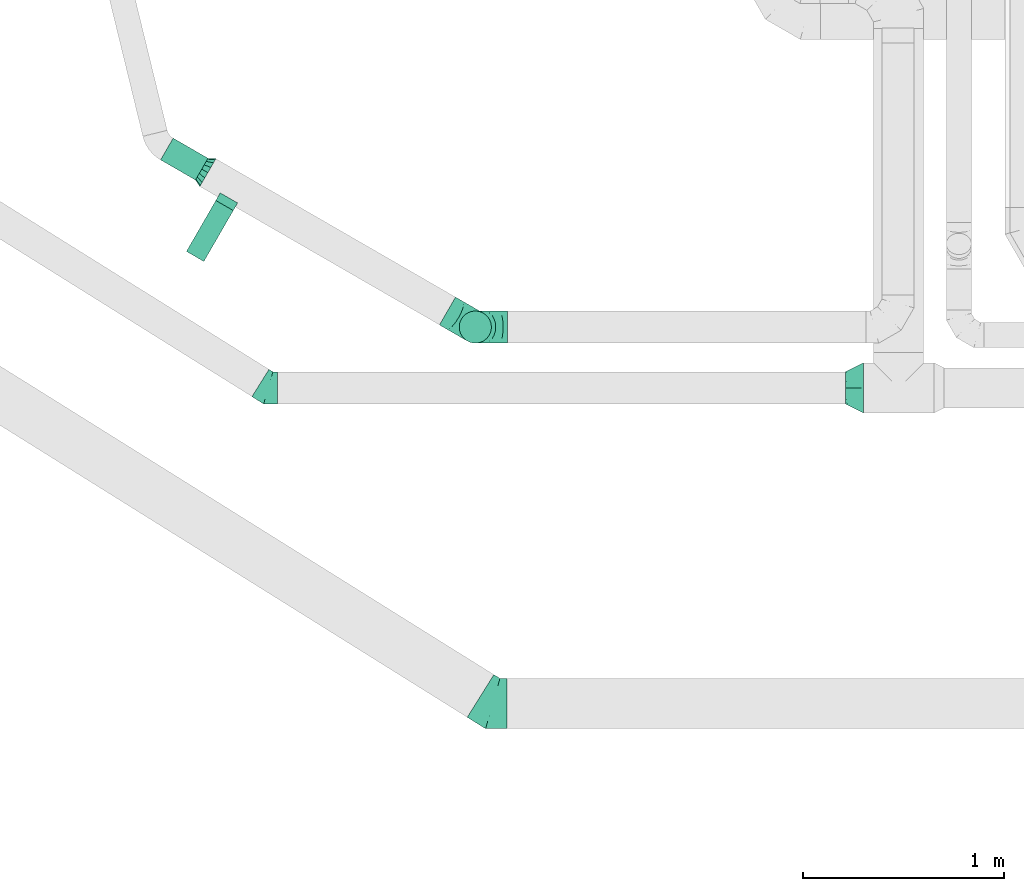
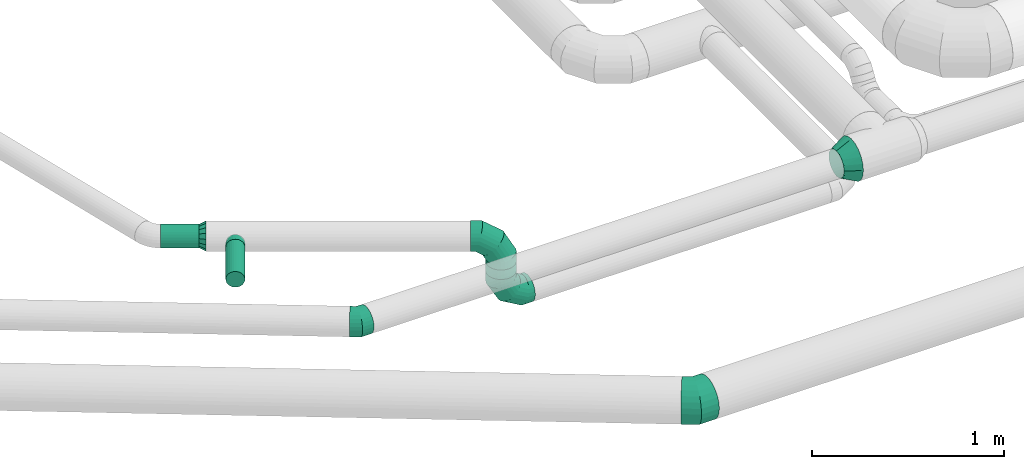
# One storey, part 34 of 92: 7 flow fittings, 3 flow segments.
"""IFC2X3 building model written with IfcOpenShell, lengths in millimetres."""

from ifc_helpers import new_model, entity, si_unit, converted_unit, derived_unit, direction, frame, origin, origin_2d_with_axis, place, context, subcontext, project, spatial, circle, extrude, faceted_brep, source, transform, mapped, material, type_object, type_shapes, element, save


model = new_model("IFC2X3")

# Units and contexts
model_context = context("Model", 3, precision=0.01, world=origin(), true_north=direction((6.12303176911189e-17, 1.0)))
body_context = subcontext(model_context, "Body", "Model", "MODEL_VIEW")
ifc_project = project(units=[si_unit("LENGTHUNIT", "METRE", prefix="MILLI"), si_unit("AREAUNIT", "SQUARE_METRE"), si_unit("VOLUMEUNIT", "CUBIC_METRE"), converted_unit("PLANEANGLEUNIT", "DEGREE", entity("IfcRatioMeasure", 0.0174532925199433), si_unit("PLANEANGLEUNIT", "RADIAN"), dimensions=[0, 0, 0, 0, 0, 0, 0]), si_unit("MASSUNIT", "GRAM", prefix="KILO"), derived_unit("MASSDENSITYUNIT", [(si_unit("MASSUNIT", "GRAM", prefix="KILO"), 1), (si_unit("LENGTHUNIT", "METRE"), -3)]), derived_unit("MOMENTOFINERTIAUNIT", [(si_unit("LENGTHUNIT", "METRE"), 4)]), si_unit("TIMEUNIT", "SECOND"), si_unit("FREQUENCYUNIT", "HERTZ"), si_unit("THERMODYNAMICTEMPERATUREUNIT", "DEGREE_CELSIUS"), derived_unit("THERMALTRANSMITTANCEUNIT", [(si_unit("MASSUNIT", "GRAM", prefix="KILO"), 1), (si_unit("THERMODYNAMICTEMPERATUREUNIT", "KELVIN"), -1), (si_unit("TIMEUNIT", "SECOND"), -3)]), derived_unit("VOLUMETRICFLOWRATEUNIT", [(si_unit("LENGTHUNIT", "METRE"), 3), (si_unit("TIMEUNIT", "SECOND"), -1)]), derived_unit("MASSFLOWRATEUNIT", [(si_unit("MASSUNIT", "GRAM", prefix="KILO"), 1), (si_unit("TIMEUNIT", "SECOND"), -1)]), derived_unit("ROTATIONALFREQUENCYUNIT", [(si_unit("TIMEUNIT", "SECOND"), -1)]), si_unit("ELECTRICCURRENTUNIT", "AMPERE"), si_unit("ELECTRICVOLTAGEUNIT", "VOLT"), si_unit("POWERUNIT", "WATT"), si_unit("FORCEUNIT", "NEWTON", prefix="KILO"), si_unit("ILLUMINANCEUNIT", "LUX"), si_unit("LUMINOUSFLUXUNIT", "LUMEN"), si_unit("LUMINOUSINTENSITYUNIT", "CANDELA"), derived_unit("USERDEFINED", [(si_unit("MASSUNIT", "GRAM", prefix="KILO"), -1), (si_unit("LENGTHUNIT", "METRE"), -2), (si_unit("TIMEUNIT", "SECOND"), 3), (si_unit("LUMINOUSFLUXUNIT", "LUMEN"), 1)]), derived_unit("LINEARVELOCITYUNIT", [(si_unit("LENGTHUNIT", "METRE"), 1), (si_unit("TIMEUNIT", "SECOND"), -1)]), si_unit("PRESSUREUNIT", "PASCAL"), derived_unit("USERDEFINED", [(si_unit("LENGTHUNIT", "METRE"), -2), (si_unit("MASSUNIT", "GRAM", prefix="KILO"), 1), (si_unit("TIMEUNIT", "SECOND"), -2)]), derived_unit("LINEARFORCEUNIT", [(si_unit("MASSUNIT", "GRAM", prefix="KILO"), 1), (si_unit("LENGTHUNIT", "METRE"), 1), (si_unit("TIMEUNIT", "SECOND"), -2), (si_unit("LENGTHUNIT", "METRE"), -1)]), derived_unit("PLANARFORCEUNIT", [(si_unit("MASSUNIT", "GRAM", prefix="KILO"), 1), (si_unit("LENGTHUNIT", "METRE"), 1), (si_unit("TIMEUNIT", "SECOND"), -2), (si_unit("LENGTHUNIT", "METRE"), -2)])], contexts=[model_context])

# Site, building, storey
site_placement = place(None, origin())
site = spatial("IfcSite", under=ifc_project, at=site_placement, CompositionType="ELEMENT")
building_placement = place(site_placement, origin())
building = spatial("IfcBuilding", under=site, at=building_placement, CompositionType="ELEMENT")
storey_placement = place(building_placement, frame((0.0, 0.0, 4200.0)))
storey = spatial("IfcBuildingStorey", under=building, at=storey_placement, CompositionType="ELEMENT", Elevation=4200.0)

# Flow segments
duct_segment_type = type_object("IfcDuctSegmentType", PredefinedType="NOTDEFINED")
flow_segment_1_placement = place(storey_placement, frame((4217.78, 12269.42, 3235.9)))
element("IfcFlowSegment", 1, at=flow_segment_1_placement, inside=storey, type_object=duct_segment_type, context=body_context, shape_type="SweptSolid", body=[
    extrude(circle(Radius=62.5, at=origin_2d_with_axis()), frame((206.46, 55.72, 64.1), z_axis=(-0.866025403784461, 0.499999999999962, 0.0), x_axis=(0.499999999999962, 0.866025403784461, 0.0)), (0.0, 0.0, 1.0), 200.470374089768),
])
flow_segment_2_placement = place(storey_placement, frame((4346.45, 11864.31, 3248.4)))
element("IfcFlowSegment", 2, at=flow_segment_2_placement, inside=storey, type_object=duct_segment_type, context=body_context, shape_type="SweptSolid", body=[
    extrude(circle(Radius=50.0, at=origin_2d_with_axis()), frame((44.9, 26.6, 51.6), z_axis=(0.499999999999714, 0.866025403784604, 0.0), x_axis=(-0.866025403784604, 0.499999999999714, 0.0)), (0.0, 0.0, 1.0), 292.499999999979),
])
flow_segment_3_placement = place(storey_placement, frame((5703.18, 11458.04, 3080.0)))
element("IfcFlowSegment", 3, at=flow_segment_3_placement, inside=storey, type_object=duct_segment_type, context=body_context, shape_type="SweptSolid", body=[
    extrude(circle(Radius=80.0, at=origin_2d_with_axis()), frame((81.6, 81.6, 0.0), z_axis=(0.0, 0.0, 1.0), x_axis=(-0.50000000000002, -0.866025403784427, 0.0)), (0.0, 0.0, 1.0), 60.0000000001011),
])

# Flow fittings
ifc_material = material()
duct_fitting_type_1 = type_object("IfcDuctFittingType", PredefinedType="NOTDEFINED", material=ifc_material)
shared_shape_1 = source(origin(), body_context, "Body", "Brep", [
    faceted_brep([(-160.0, 0.0, -80.0), (-160.0, -20.71, -77.27), (-160.0, -40.0, -69.28), (-160.0, -56.57, -56.57), (-160.0, -69.28, -40.0), (-160.0, -77.27, -20.71), (-160.0, -80.0, 0.0), (-160.0, -77.27, 20.71), (-160.0, -69.28, 40.0), (-160.0, -56.57, 56.57), (-160.0, -40.0, 69.28), (-160.0, -20.71, 77.27), (-160.0, 0.0, 80.0), (-160.0, 20.71, 77.27), (-160.0, 40.0, 69.28), (-160.0, 56.57, 56.57), (-160.0, 69.28, 40.0), (-160.0, 77.27, 20.71), (-160.0, 80.0, 0.0), (-160.0, 77.27, -20.71), (-160.0, 69.28, -40.0), (-160.0, 56.57, -56.57), (-160.0, 40.0, -69.28), (-160.0, 20.71, -77.27), (-122.68, 20.71, 77.27), (-127.85, 40.0, 69.28), (-117.13, 0.0, 80.0), (-132.29, 56.57, 56.57), (-137.83, 77.27, 20.71), (-138.56, 80.0, 0.0), (-135.69, 69.28, 40.0), (-135.69, 69.28, -40.0), (-132.29, 56.57, -56.57), (-137.83, 77.27, -20.71), (-122.68, 20.71, -77.27), (-117.13, 0.0, -80.0), (-127.85, 40.0, -69.28), (-111.58, -20.71, -77.27), (-106.41, -40.0, -69.28), (-101.97, -56.57, -56.57), (-98.56, -69.28, -40.0), (-96.42, -77.27, -20.71), (-95.69, -80.0, 0.0), (-96.42, -77.27, 20.71), (-98.56, -69.28, 40.0), (-101.97, -56.57, 56.57), (-106.41, -40.0, 69.28), (-111.58, -20.71, 77.27), (-58.03, 58.03, 77.27), (-72.15, 72.15, 69.28), (-42.87, 42.87, 80.0), (-84.28, 84.28, 56.57), (-93.59, 93.59, 40.0), (-99.44, 99.44, 20.71), (-101.44, 101.44, 0.0), (-99.44, 99.44, -20.71), (-93.59, 93.59, -40.0), (-84.28, 84.28, -56.57), (-58.03, 58.03, -77.27), (-42.87, 42.87, -80.0), (-72.15, 72.15, -69.28), (-27.71, 27.71, -77.27), (-13.59, 13.59, -69.28), (-1.46, 1.46, -56.57), (7.85, -7.85, -40.0), (13.7, -13.7, -20.71), (15.69, -15.69, 0.0), (13.7, -13.7, 20.71), (7.85, -7.85, 40.0), (-1.46, 1.46, 56.57), (-13.59, 13.59, 69.28), (-27.71, 27.71, 77.27), (-20.71, 122.68, 77.27), (-40.0, 127.85, 69.28), (0.0, 117.13, 80.0), (-56.57, 132.29, 56.57), (-69.28, 135.69, 40.0), (-77.27, 137.83, 20.71), (-80.0, 138.56, 0.0), (-77.27, 137.83, -20.71), (-69.28, 135.69, -40.0), (-56.57, 132.29, -56.57), (-20.71, 122.68, -77.27), (0.0, 117.13, -80.0), (-40.0, 127.85, -69.28), (20.71, 111.58, -77.27), (40.0, 106.41, -69.28), (56.57, 101.97, -56.57), (69.28, 98.56, -40.0), (77.27, 96.42, -20.71), (80.0, 95.69, 0.0), (77.27, 96.42, 20.71), (69.28, 98.56, 40.0), (56.57, 101.97, 56.57), (40.0, 106.41, 69.28), (20.71, 111.58, 77.27), (-20.71, 160.0, -77.27), (-40.0, 160.0, -69.28), (-56.57, 160.0, -56.57), (-69.28, 160.0, -40.0), (-77.27, 160.0, -20.71), (-80.0, 160.0, 0.0), (-77.27, 160.0, 20.71), (-69.28, 160.0, 40.0), (-56.57, 160.0, 56.57), (-40.0, 160.0, 69.28), (-20.71, 160.0, 77.27), (0.0, 160.0, 80.0), (20.71, 160.0, 77.27), (40.0, 160.0, 69.28), (56.57, 160.0, 56.57), (69.28, 160.0, 40.0), (77.27, 160.0, 20.71), (80.0, 160.0, 0.0), (77.27, 160.0, -20.71), (69.28, 160.0, -40.0), (56.57, 160.0, -56.57), (40.0, 160.0, -69.28), (20.71, 160.0, -77.27), (0.0, 160.0, -80.0)], [[[0, 1, 2, 3, 4, 5, 6, 7, 8, 9, 10, 11, 12, 13, 14, 15, 16, 17, 18, 19, 20, 21, 22, 23]], [[24, 25, 14, 13]], [[26, 24, 13, 12]], [[14, 25, 27, 15]], [[28, 29, 18, 17]], [[30, 28, 17, 16]], [[15, 27, 30, 16]], [[20, 31, 32, 21]], [[33, 31, 20, 19]], [[18, 29, 33, 19]], [[34, 35, 0, 23]], [[36, 34, 23, 22]], [[32, 36, 22, 21]], [[1, 0, 35, 37]], [[2, 1, 37, 38]], [[3, 2, 38, 39]], [[5, 4, 40, 41]], [[6, 5, 41, 42]], [[39, 40, 4, 3]], [[6, 42, 43, 7]], [[7, 43, 44, 8]], [[8, 44, 45, 9]], [[9, 45, 46, 10]], [[10, 46, 47, 11]], [[26, 12, 11, 47]], [[48, 49, 25, 24]], [[50, 48, 24, 26]], [[27, 25, 49, 51]], [[52, 53, 28, 30]], [[51, 52, 30, 27]], [[29, 28, 53, 54]], [[55, 56, 31, 33]], [[54, 55, 33, 29]], [[32, 31, 56, 57]], [[58, 59, 35, 34]], [[60, 58, 34, 36]], [[57, 60, 36, 32]], [[37, 35, 59, 61]], [[38, 37, 61, 62]], [[39, 38, 62, 63]], [[41, 40, 64, 65]], [[42, 41, 65, 66]], [[63, 64, 40, 39]], [[43, 42, 66, 67]], [[44, 43, 67, 68]], [[68, 69, 45, 44]], [[46, 45, 69, 70]], [[47, 46, 70, 71]], [[26, 47, 71, 50]], [[72, 73, 49, 48]], [[74, 72, 48, 50]], [[51, 49, 73, 75]], [[76, 77, 53, 52]], [[75, 76, 52, 51]], [[54, 53, 77, 78]], [[79, 80, 56, 55]], [[78, 79, 55, 54]], [[57, 56, 80, 81]], [[82, 83, 59, 58]], [[84, 82, 58, 60]], [[81, 84, 60, 57]], [[61, 59, 83, 85]], [[62, 61, 85, 86]], [[63, 62, 86, 87]], [[65, 64, 88, 89]], [[66, 65, 89, 90]], [[87, 88, 64, 63]], [[67, 66, 90, 91]], [[68, 67, 91, 92]], [[92, 93, 69, 68]], [[70, 69, 93, 94]], [[71, 70, 94, 95]], [[50, 71, 95, 74]], [[96, 97, 98, 99, 100, 101, 102, 103, 104, 105, 106, 107, 108, 109, 110, 111, 112, 113, 114, 115, 116, 117, 118, 119]], [[72, 74, 107, 106]], [[73, 72, 106, 105]], [[75, 73, 105, 104]], [[77, 76, 103, 102]], [[78, 77, 102, 101]], [[75, 104, 103, 76]], [[78, 101, 100, 79]], [[79, 100, 99, 80]], [[80, 99, 98, 81]], [[84, 97, 96, 82]], [[82, 96, 119, 83]], [[84, 81, 98, 97]], [[118, 117, 86, 85]], [[119, 118, 85, 83]], [[116, 87, 86, 117]], [[88, 115, 114, 89]], [[89, 114, 113, 90]], [[115, 88, 87, 116]], [[112, 111, 92, 91]], [[113, 112, 91, 90]], [[111, 110, 93, 92]], [[95, 94, 109, 108]], [[74, 95, 108, 107]], [[110, 109, 94, 93]]]),
])
type_shapes(duct_fitting_type_1, [shared_shape_1])
for number, where, z_axis, x_axis in (
    (4, (5784.77, 11539.63, 3300.0), (0.50000000000002, 0.866025403784427, 0.0), (0.866025403784427, -0.50000000000002, 0.0)),
    (5, (5784.77, 11539.63, 2920.0), (0.0, -1.0, 0.0), (0.0, 0.0, -1.0)),
):
    element("IfcFlowFitting", number, at=place(storey_placement, frame(where, z_axis=z_axis, x_axis=x_axis)), inside=storey, type_object=duct_fitting_type_1, material=ifc_material, context=body_context, shape_type="MappedRepresentation", body=[
        mapped(shared_shape_1, transform((0.0, 0.0, 0.0), scale=1.0)),
    ])
duct_fitting_type_2 = type_object("IfcDuctFittingType", PredefinedType="NOTDEFINED", material=ifc_material)
shared_shape_2 = source(origin(), body_context, "Body", "Brep", [
    faceted_brep([(35.0, 0.0, -80.0), (35.0, 12.81, -77.45), (35.0, 30.61, -73.91), (35.0, 43.59, -65.24), (35.0, 56.57, -56.57), (35.0, 65.24, -43.59), (35.0, 73.91, -30.61), (35.0, 76.96, -15.31), (35.0, 80.0, 0.0), (35.0, 77.45, 12.81), (35.0, 73.91, 30.61), (35.0, 65.24, 43.59), (35.0, 56.57, 56.57), (35.0, 43.59, 65.24), (35.0, 30.61, 73.91), (35.0, 15.31, 76.96), (35.0, 0.0, 80.0), (35.0, -12.81, 77.45), (35.0, -30.61, 73.91), (35.0, -43.59, 65.24), (35.0, -56.57, 56.57), (35.0, -65.24, 43.59), (35.0, -73.91, 30.61), (35.0, -76.96, 15.31), (35.0, -80.0, 0.0), (35.0, -77.45, -12.81), (35.0, -73.91, -30.61), (35.0, -65.24, -43.59), (35.0, -56.57, -56.57), (35.0, -43.59, -65.24), (35.0, -30.61, -73.91), (35.0, -15.31, -76.96), (0.0, -23.92, -57.74), (0.0, -34.06, -50.97), (0.0, -44.19, -44.19), (0.0, -50.97, -34.06), (0.0, -57.74, -23.92), (0.0, -60.12, -11.96), (0.0, -62.5, 0.0), (0.0, -60.12, 11.96), (0.0, -57.74, 23.92), (0.0, -50.97, 34.06), (0.0, -44.19, 44.19), (0.0, -34.06, 50.97), (0.0, -23.92, 57.74), (0.0, -11.96, 60.12), (0.0, 0.0, 62.5), (0.0, 11.96, 60.12), (0.0, 23.92, 57.74), (0.0, 34.06, 50.97), (0.0, 44.19, 44.19), (0.0, 50.97, 34.06), (0.0, 57.74, 23.92), (0.0, 60.12, 11.96), (0.0, 62.5, 0.0), (0.0, 60.12, -11.96), (0.0, 57.74, -23.92), (0.0, 50.97, -34.06), (0.0, 44.19, -44.19), (0.0, 34.06, -50.97), (0.0, 23.92, -57.74), (0.0, 11.96, -60.12), (0.0, 0.0, -62.5), (0.0, -11.96, -60.12)], [[[0, 1, 2, 3, 4, 5, 6, 7, 8, 9, 10, 11, 12, 13, 14, 15, 16, 17, 18, 19, 20, 21, 22, 23, 24, 25, 26, 27, 28, 29, 30, 31]], [[32, 33, 34, 35, 36, 37, 38, 39, 40, 41, 42, 43, 44, 45, 46, 47, 48, 49, 50, 51, 52, 53, 54, 55, 56, 57, 58, 59, 60, 61, 62, 63]], [[10, 9, 8, 54, 53, 52]], [[11, 10, 52, 51, 50, 12]], [[48, 14, 13, 12, 50, 49]], [[46, 16, 15, 14, 48, 47]], [[18, 17, 16, 46, 45, 44]], [[19, 18, 44, 43, 42, 20]], [[40, 22, 21, 20, 42, 41]], [[38, 24, 23, 22, 40, 39]], [[26, 25, 24, 38, 37, 36]], [[27, 26, 36, 35, 34, 28]], [[32, 30, 29, 28, 34, 33]], [[62, 0, 31, 30, 32, 63]], [[2, 1, 0, 62, 61, 60]], [[3, 2, 60, 59, 58, 4]], [[56, 6, 5, 4, 58, 57]], [[54, 8, 7, 6, 56, 55]]]),
])
type_shapes(duct_fitting_type_2, [shared_shape_2])
flow_fitting_1_placement = place(storey_placement, frame((4424.23, 12325.14, 3300.0), z_axis=(0.0, 0.0, 1.0), x_axis=(0.866025403784431, -0.500000000000013, 0.0)))
element("IfcFlowFitting", 6, at=flow_fitting_1_placement, inside=storey, type_object=duct_fitting_type_2, material=ifc_material, context=body_context, shape_type="MappedRepresentation", body=[
    mapped(shared_shape_2, transform((0.0, 0.0, 0.0), scale=1.0)),
])
duct_fitting_type_3 = type_object("IfcDuctFittingType", PredefinedType="NOTDEFINED", material=ifc_material)
shared_shape_3 = source(origin(), body_context, "Body", "Brep", [
    faceted_brep([(20.0, 0.0, -50.0), (20.0, 12.94, -48.3), (20.0, 25.0, -43.3), (20.0, 35.36, -35.36), (20.0, 43.3, -25.0), (20.0, 48.3, -12.94), (20.0, 50.0, 0.0), (20.0, 48.3, 12.94), (20.0, 43.3, 25.0), (20.0, 35.36, 35.36), (20.0, 25.0, 43.3), (20.0, 12.94, 48.3), (20.0, 0.0, 50.0), (20.0, -12.94, 48.3), (20.0, -25.0, 43.3), (20.0, -35.36, 35.36), (20.0, -43.3, 25.0), (20.0, -48.3, 12.94), (20.0, -50.0, 0.0), (20.0, -48.3, -12.94), (20.0, -43.3, -25.0), (20.0, -35.36, -35.36), (20.0, -25.0, -43.3), (20.0, -12.94, -48.3), (0.0, 0.0, 50.0), (-23.65, 0.0, 50.0), (-23.65, -12.94, 48.3), (0.0, -12.94, 48.3), (-23.65, -25.0, 43.3), (0.0, -25.0, 43.3), (0.0, -35.36, 35.36), (-23.65, -35.36, 35.36), (0.0, -43.3, 25.0), (-23.65, -43.3, 25.0), (-23.65, -48.3, 12.94), (0.0, -48.3, 12.94), (-23.65, -50.0, 0.0), (0.0, -50.0, 0.0), (-23.65, -48.3, -12.94), (0.0, -48.3, -12.94), (-23.65, -43.3, -25.0), (0.0, -43.3, -25.0), (0.0, -35.36, -35.36), (-23.65, -35.36, -35.36), (0.0, -25.0, -43.3), (-23.65, -25.0, -43.3), (-23.65, -12.94, -48.3), (0.0, -12.94, -48.3), (-23.65, 0.0, -50.0), (0.0, 0.0, -50.0), (-23.65, 12.94, -48.3), (0.0, 12.94, -48.3), (-23.65, 25.0, -43.3), (0.0, 25.0, -43.3), (0.0, 35.36, -35.36), (-23.65, 35.36, -35.36), (0.0, 43.3, -25.0), (-23.65, 43.3, -25.0), (-23.65, 48.3, -12.94), (0.0, 48.3, -12.94), (-23.65, 50.0, 0.0), (0.0, 50.0, 0.0), (-23.65, 48.3, 12.94), (0.0, 48.3, 12.94), (-23.65, 43.3, 25.0), (0.0, 43.3, 25.0), (0.0, 35.36, 35.36), (-23.65, 35.36, 35.36), (0.0, 25.0, 43.3), (-23.65, 25.0, 43.3), (-23.65, 12.94, 48.3), (0.0, 12.94, 48.3)], [[[0, 1, 2, 3, 4, 5, 6, 7, 8, 9, 10, 11, 12, 13, 14, 15, 16, 17, 18, 19, 20, 21, 22, 23]], [[13, 12, 24, 25, 26, 27]], [[14, 13, 27, 26, 28, 29]], [[30, 15, 14, 29, 28, 31]], [[17, 16, 32, 33, 34, 35]], [[18, 17, 35, 34, 36, 37]], [[32, 16, 15, 30, 31, 33]], [[19, 18, 37, 36, 38, 39]], [[20, 19, 39, 38, 40, 41]], [[42, 21, 20, 41, 40, 43]], [[23, 22, 44, 45, 46, 47]], [[0, 23, 47, 46, 48, 49]], [[44, 22, 21, 42, 43, 45]], [[1, 0, 49, 48, 50, 51]], [[2, 1, 51, 50, 52, 53]], [[54, 3, 2, 53, 52, 55]], [[5, 4, 56, 57, 58, 59]], [[6, 5, 59, 58, 60, 61]], [[56, 4, 3, 54, 55, 57]], [[7, 6, 61, 60, 62, 63]], [[8, 7, 63, 62, 64, 65]], [[66, 9, 8, 65, 64, 67]], [[11, 10, 68, 69, 70, 71]], [[12, 11, 71, 70, 25, 24]], [[68, 10, 9, 66, 67, 69]], [[46, 45, 43, 40, 38, 36, 34, 33, 31, 28, 26, 25, 70, 69, 67, 64, 62, 60, 58, 57, 55, 52, 50, 48]]]),
])
type_shapes(duct_fitting_type_3, [shared_shape_3])
flow_fitting_2_placement = place(storey_placement, frame((4547.6, 12161.54, 3300.0), z_axis=(0.0, 0.0, -1.0), x_axis=(-0.499999999999978, -0.866025403784451, 0.0)))
element("IfcFlowFitting", 7, at=flow_fitting_2_placement, inside=storey, type_object=duct_fitting_type_3, material=ifc_material, context=body_context, shape_type="MappedRepresentation", body=[
    mapped(shared_shape_3, transform((0.0, 0.0, 0.0), scale=1.0)),
])
duct_fitting_type_4 = type_object("IfcDuctFittingType", PredefinedType="NOTDEFINED", material=ifc_material)
shared_shape_4 = source(origin(), body_context, "Body", "Brep", [
    faceted_brep([(-45.88, 0.0, -80.0), (-45.88, -20.71, -77.27), (-45.88, -40.0, -69.28), (-45.88, -56.57, -56.57), (-45.88, -69.28, -40.0), (-45.88, -77.27, -20.71), (-45.88, -80.0, 0.0), (-45.88, -77.27, 20.71), (-45.88, -69.28, 40.0), (-45.88, -56.57, 56.57), (-45.88, -40.0, 69.28), (-45.88, -20.71, 77.27), (-45.88, 0.0, 80.0), (-45.88, 20.71, 77.27), (-45.88, 40.0, 69.28), (-45.88, 56.57, 56.57), (-45.88, 69.28, 40.0), (-45.88, 77.27, 20.71), (-45.88, 80.0, 0.0), (-45.88, 77.27, -20.71), (-45.88, 69.28, -40.0), (-45.88, 56.57, -56.57), (-45.88, 40.0, -69.28), (-45.88, 20.71, -77.27), (-5.94, 20.71, 77.27), (-11.47, 40.0, 69.28), (0.0, 0.0, 80.0), (-16.22, 56.57, 56.57), (-22.16, 77.27, 20.71), (-22.94, 80.0, 0.0), (-19.87, 69.28, 40.0), (-19.87, 69.28, -40.0), (-16.22, 56.57, -56.57), (-22.16, 77.27, -20.71), (-5.94, 20.71, -77.27), (0.0, 0.0, -80.0), (-11.47, 40.0, -69.28), (5.94, -20.71, -77.27), (11.47, -40.0, -69.28), (16.22, -56.57, -56.57), (19.87, -69.28, -40.0), (22.16, -77.27, -20.71), (22.94, -80.0, 0.0), (22.16, -77.27, 20.71), (19.87, -69.28, 40.0), (16.22, -56.57, 56.57), (11.47, -40.0, 69.28), (5.94, -20.71, 77.27), (38.91, 24.31, 80.0), (27.94, 41.87, 77.27), (17.71, 58.23, 69.28), (8.93, 72.28, 56.57), (2.19, 83.07, 40.0), (-2.04, 89.84, 20.71), (-3.49, 92.16, 0.0), (-2.04, 89.84, -20.71), (2.19, 83.07, -40.0), (8.93, 72.28, -56.57), (17.71, 58.23, -69.28), (27.94, 41.87, -77.27), (38.91, 24.31, -80.0), (49.88, 6.75, -77.27), (60.1, -9.61, -69.28), (68.88, -23.66, -56.57), (75.62, -34.44, -40.0), (79.86, -41.22, -20.71), (81.3, -43.53, 0.0), (79.86, -41.22, 20.71), (75.62, -34.44, 40.0), (68.88, -23.66, 56.57), (60.1, -9.61, 69.28), (49.88, 6.75, 77.27)], [[[0, 1, 2, 3, 4, 5, 6, 7, 8, 9, 10, 11, 12, 13, 14, 15, 16, 17, 18, 19, 20, 21, 22, 23]], [[24, 25, 14, 13]], [[26, 24, 13, 12]], [[14, 25, 27, 15]], [[28, 29, 18, 17]], [[30, 28, 17, 16]], [[15, 27, 30, 16]], [[20, 31, 32, 21]], [[33, 31, 20, 19]], [[18, 29, 33, 19]], [[34, 35, 0, 23]], [[36, 34, 23, 22]], [[32, 36, 22, 21]], [[1, 0, 35, 37]], [[2, 1, 37, 38]], [[38, 39, 3, 2]], [[5, 4, 40, 41]], [[6, 5, 41, 42]], [[39, 40, 4, 3]], [[6, 42, 43, 7]], [[7, 43, 44, 8]], [[8, 44, 45, 9]], [[9, 45, 46, 10]], [[10, 46, 47, 11]], [[26, 12, 11, 47]], [[24, 26, 48, 49]], [[25, 24, 49, 50]], [[27, 25, 50, 51]], [[28, 30, 52, 53]], [[29, 28, 53, 54]], [[27, 51, 52, 30]], [[29, 54, 55, 33]], [[33, 55, 56, 31]], [[31, 56, 57, 32]], [[36, 58, 59, 34]], [[34, 59, 60, 35]], [[36, 32, 57, 58]], [[61, 62, 38, 37]], [[60, 61, 37, 35]], [[63, 39, 38, 62]], [[40, 64, 65, 41]], [[41, 65, 66, 42]], [[64, 40, 39, 63]], [[43, 42, 66, 67]], [[44, 43, 67, 68]], [[68, 69, 45, 44]], [[47, 46, 70, 71]], [[26, 47, 71, 48]], [[69, 70, 46, 45]], [[59, 58, 57, 56, 55, 54, 53, 52, 51, 50, 49, 48, 71, 70, 69, 68, 67, 66, 65, 64, 63, 62, 61, 60]]]),
])
type_shapes(duct_fitting_type_4, [shared_shape_4])
flow_fitting_3_placement = place(storey_placement, frame((4755.03, 11237.19, 3300.0), z_axis=(0.0, 0.0, 1.0), x_axis=(0.84805274377757, -0.529911826412031, 0.0)))
element("IfcFlowFitting", 8, at=flow_fitting_3_placement, inside=storey, type_object=duct_fitting_type_4, material=ifc_material, context=body_context, shape_type="MappedRepresentation", body=[
    mapped(shared_shape_4, transform((0.0, 0.0, 0.0), scale=1.0)),
])
duct_fitting_type_5 = type_object("IfcDuctFittingType", PredefinedType="NOTDEFINED", material=ifc_material)
shared_shape_5 = source(origin(), body_context, "Body", "Brep", [
    faceted_brep([(-71.69, 0.0, -125.0), (-71.69, -32.35, -120.74), (-71.69, -62.5, -108.25), (-71.69, -88.39, -88.39), (-71.69, -108.25, -62.5), (-71.69, -120.74, -32.35), (-71.69, -125.0, 0.0), (-71.69, -120.74, 32.35), (-71.69, -108.25, 62.5), (-71.69, -88.39, 88.39), (-71.69, -62.5, 108.25), (-71.69, -32.35, 120.74), (-71.69, 0.0, 125.0), (-71.69, 32.35, 120.74), (-71.69, 62.5, 108.25), (-71.69, 88.39, 88.39), (-71.69, 108.25, 62.5), (-71.69, 120.74, 32.35), (-71.69, 125.0, 0.0), (-71.69, 120.74, -32.35), (-71.69, 108.25, -62.5), (-71.69, 88.39, -88.39), (-71.69, 62.5, -108.25), (-71.69, 32.35, -120.74), (-9.28, 32.35, 120.74), (-17.92, 62.5, 108.25), (0.0, 0.0, 125.0), (-25.34, 88.39, 88.39), (-31.04, 108.25, 62.5), (-34.62, 120.74, 32.35), (-35.84, 125.0, 0.0), (-34.62, 120.74, -32.35), (-31.04, 108.25, -62.5), (-25.34, 88.39, -88.39), (-9.28, 32.35, -120.74), (0.0, 0.0, -125.0), (-17.92, 62.5, -108.25), (9.28, -32.35, -120.74), (17.92, -62.5, -108.25), (25.34, -88.39, -88.39), (31.04, -108.25, -62.5), (34.62, -120.74, -32.35), (35.84, -125.0, 0.0), (34.62, -120.74, 32.35), (31.04, -108.25, 62.5), (25.34, -88.39, 88.39), (17.92, -62.5, 108.25), (9.28, -32.35, 120.74), (60.79, 37.99, 125.0), (43.65, 65.42, 120.74), (27.67, 90.99, 108.25), (13.95, 112.94, 88.39), (3.43, 129.79, 62.5), (-3.19, 140.38, 32.35), (-5.45, 143.99, 0.0), (-3.19, 140.38, -32.35), (3.43, 129.79, -62.5), (13.95, 112.94, -88.39), (27.67, 90.99, -108.25), (43.65, 65.42, -120.74), (60.79, 37.99, -125.0), (77.94, 10.55, -120.74), (93.91, -15.02, -108.25), (107.63, -36.97, -88.39), (118.16, -53.82, -62.5), (124.77, -64.41, -32.35), (127.03, -68.02, 0.0), (124.77, -64.41, 32.35), (118.16, -53.82, 62.5), (107.63, -36.97, 88.39), (93.91, -15.02, 108.25), (77.94, 10.55, 120.74)], [[[0, 1, 2, 3, 4, 5, 6, 7, 8, 9, 10, 11, 12, 13, 14, 15, 16, 17, 18, 19, 20, 21, 22, 23]], [[24, 25, 14, 13]], [[26, 24, 13, 12]], [[27, 15, 14, 25]], [[28, 29, 17, 16]], [[28, 16, 15, 27]], [[30, 18, 17, 29]], [[31, 32, 20, 19]], [[30, 31, 19, 18]], [[21, 20, 32, 33]], [[34, 35, 0, 23]], [[36, 34, 23, 22]], [[33, 36, 22, 21]], [[1, 0, 35, 37]], [[2, 1, 37, 38]], [[38, 39, 3, 2]], [[5, 4, 40, 41]], [[6, 5, 41, 42]], [[39, 40, 4, 3]], [[6, 42, 43, 7]], [[7, 43, 44, 8]], [[8, 44, 45, 9]], [[9, 45, 46, 10]], [[10, 46, 47, 11]], [[26, 12, 11, 47]], [[24, 26, 48, 49]], [[25, 24, 49, 50]], [[27, 25, 50, 51]], [[29, 28, 52, 53]], [[30, 29, 53, 54]], [[51, 52, 28, 27]], [[55, 56, 32, 31]], [[54, 55, 31, 30]], [[57, 33, 32, 56]], [[36, 58, 59, 34]], [[34, 59, 60, 35]], [[58, 36, 33, 57]], [[35, 60, 61, 37]], [[37, 61, 62, 38]], [[63, 39, 38, 62]], [[40, 64, 65, 41]], [[41, 65, 66, 42]], [[64, 40, 39, 63]], [[43, 42, 66, 67]], [[44, 43, 67, 68]], [[68, 69, 45, 44]], [[47, 46, 70, 71]], [[26, 47, 71, 48]], [[69, 70, 46, 45]], [[59, 58, 57, 56, 55, 54, 53, 52, 51, 50, 49, 48, 71, 70, 69, 68, 67, 66, 65, 64, 63, 62, 61, 60]]]),
])
type_shapes(duct_fitting_type_5, [shared_shape_5])
flow_fitting_4_placement = place(storey_placement, frame((5871.59, 9667.14, 3360.0), z_axis=(0.0, 0.0, 1.0), x_axis=(0.848052743777568, -0.529911826412034, 0.0)))
element("IfcFlowFitting", 9, at=flow_fitting_4_placement, inside=storey, type_object=duct_fitting_type_5, material=ifc_material, context=body_context, shape_type="MappedRepresentation", body=[
    mapped(shared_shape_5, transform((0.0, 0.0, 0.0), scale=1.0)),
])
duct_fitting_type_6 = type_object("IfcDuctFittingType", PredefinedType="NOTDEFINED", material=ifc_material)
shared_shape_6 = source(origin(), body_context, "Body", "Brep", [
    faceted_brep([(90.0, -73.47, -101.13), (90.0, -38.63, -118.88), (90.0, 0.0, -125.0), (90.0, 38.63, -118.88), (90.0, 73.47, -101.13), (90.0, 101.13, -73.47), (90.0, 118.88, -38.63), (90.0, 125.0, 0.0), (90.0, 118.88, 38.63), (90.0, 101.13, 73.47), (90.0, 73.47, 101.13), (90.0, 38.63, 118.88), (90.0, 0.0, 125.0), (90.0, -38.63, 118.88), (90.0, -73.47, 101.13), (90.0, -101.13, 73.47), (90.0, -118.88, 38.63), (90.0, -125.0, 0.0), (90.0, -118.88, -38.63), (90.0, -101.13, -73.47), (0.0, -30.61, -73.91), (0.0, -43.59, -65.24), (0.0, -56.57, -56.57), (0.0, -65.24, -43.59), (0.0, -73.91, -30.61), (0.0, -76.96, -15.31), (0.0, -80.0, 0.0), (0.0, -76.96, 15.31), (0.0, -73.91, 30.61), (0.0, -65.24, 43.59), (0.0, -56.57, 56.57), (0.0, -43.59, 65.24), (0.0, -30.61, 73.91), (0.0, -15.31, 76.96), (0.0, 0.0, 80.0), (0.0, 15.31, 76.96), (0.0, 30.61, 73.91), (0.0, 43.59, 65.24), (0.0, 56.57, 56.57), (0.0, 65.24, 43.59), (0.0, 73.91, 30.61), (0.0, 76.96, 15.31), (0.0, 80.0, 0.0), (0.0, 76.96, -15.31), (0.0, 73.91, -30.61), (0.0, 65.24, -43.59), (0.0, 56.57, -56.57), (0.0, 43.59, -65.24), (0.0, 30.61, -73.91), (0.0, 15.31, -76.96), (0.0, 0.0, -80.0), (0.0, -15.31, -76.96)], [[[0, 1, 2, 3, 4, 5, 6, 7, 8, 9, 10, 11, 12, 13, 14, 15, 16, 17, 18, 19]], [[20, 21, 22, 23, 24, 25, 26, 27, 28, 29, 30, 31, 32, 33, 34, 35, 36, 37, 38, 39, 40, 41, 42, 43, 44, 45, 46, 47, 48, 49, 50, 51]], [[7, 41, 8]], [[41, 40, 8]], [[40, 9, 8]], [[11, 36, 35]], [[41, 7, 42]], [[9, 40, 39, 38]], [[10, 38, 37, 36]], [[12, 35, 34]], [[11, 10, 36]], [[12, 11, 35]], [[38, 10, 9]], [[12, 33, 13]], [[33, 32, 13]], [[32, 14, 13]], [[16, 28, 27]], [[33, 12, 34]], [[14, 32, 31, 30]], [[15, 30, 29, 28]], [[17, 27, 26]], [[16, 15, 28]], [[17, 16, 27]], [[30, 15, 14]], [[17, 25, 18]], [[25, 24, 18]], [[24, 19, 18]], [[1, 20, 51]], [[25, 17, 26]], [[19, 24, 23, 22]], [[0, 22, 21, 20]], [[2, 51, 50]], [[1, 0, 20]], [[2, 1, 51]], [[22, 0, 19]], [[2, 49, 3]], [[49, 48, 3]], [[48, 4, 3]], [[6, 44, 43]], [[49, 2, 50]], [[4, 48, 47, 46]], [[5, 46, 45, 44]], [[7, 43, 42]], [[6, 5, 44]], [[7, 6, 43]], [[46, 5, 4]]]),
])
type_shapes(duct_fitting_type_6, [shared_shape_6])
flow_fitting_5_placement = place(storey_placement, frame((7625.09, 11237.19, 3300.0)))
element("IfcFlowFitting", 10, at=flow_fitting_5_placement, inside=storey, type_object=duct_fitting_type_6, material=ifc_material, context=body_context, shape_type="MappedRepresentation", body=[
    mapped(shared_shape_6, transform((0.0, 0.0, 0.0), scale=1.0)),
])

save(model, "model.ifc")
